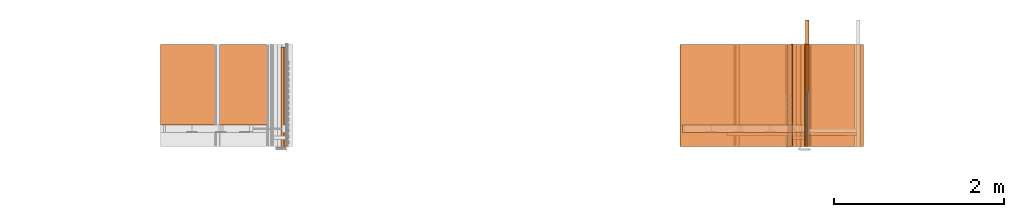
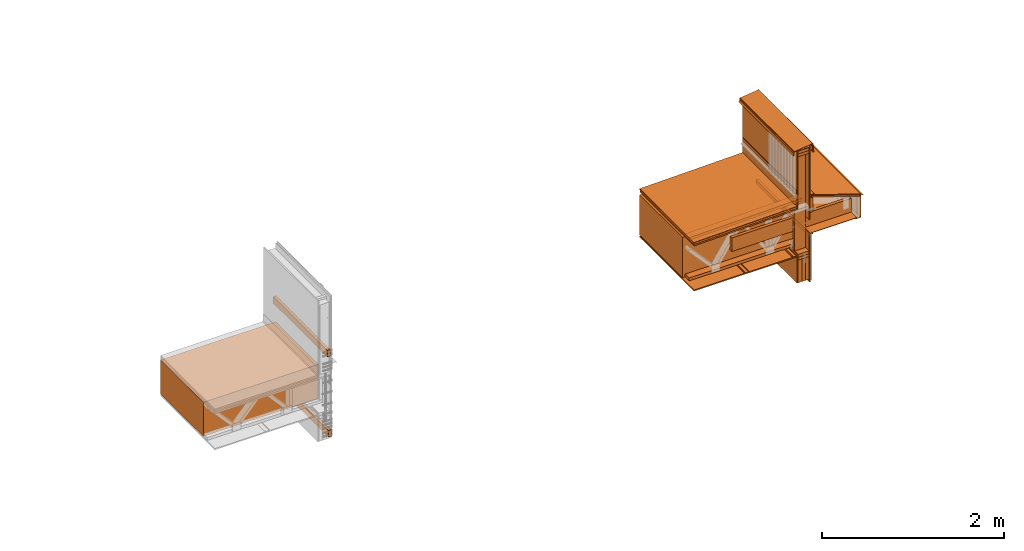
# One storey, part 3 of 22: 39 proxies.
"""IFC2X3 building model written with IfcOpenShell, lengths in feet."""

from ifc_helpers import new_model, entity, si_unit, converted_unit, frame, frame_2d, origin_with_axes, place, context, subcontext, project, spatial, polyline, rectangle, outline, extrude, shape, element, save


model = new_model("IFC2X3")

# Units and contexts
model_context = context("Model", 3, precision=1e-05)
plan_context = context("Plan", 2, precision=1e-05, world=frame_2d((0.0, 0.0, 0.0), x_axis=(1.0, 0.0, 0.0)))
body_context_1 = subcontext(model_context, "Body", "Model", "MODEL_VIEW")
body_context_2 = subcontext(model_context, "Body", "Model", "MODEL_VIEW")
ifc_project = project(units=[converted_unit("VOLUMEUNIT", "cubic foot", entity("IfcReal", 0.0283168467116885), si_unit("VOLUMEUNIT", "CUBIC_METRE"), dimensions=[3, 0, 0, 0, 0, 0, 0]), converted_unit("AREAUNIT", "square foot", entity("IfcReal", 0.09290304), si_unit("AREAUNIT", "SQUARE_METRE"), dimensions=[2, 0, 0, 0, 0, 0, 0]), converted_unit("LENGTHUNIT", "foot", entity("IfcReal", 0.3048), si_unit("LENGTHUNIT", "METRE"), dimensions=[1, 0, 0, 0, 0, 0, 0])], contexts=[model_context, plan_context])

# Site, building, storey
site_placement = place(None, origin_with_axes())
site = spatial("IfcSite", under=ifc_project, at=site_placement, CompositionType="ELEMENT")
building_placement = place(site_placement, origin_with_axes())
building = spatial("IfcBuilding", under=site, at=building_placement, Name="Building", CompositionType="ELEMENT")
storey_placement = place(building_placement, origin_with_axes())
storey = spatial("IfcBuildingStorey", under=building, at=storey_placement, Name="Storey", CompositionType="ELEMENT")

# Proxies
proxy_1_placement = place(storey_placement, frame((1612.24555468622, 1.8910506344217, -61.7362820883123), z_axis=(0.0, 0.0, 1.0), x_axis=(1.0, 0.0, 0.0)))
element("IfcBuildingElementProxy", 1, at=proxy_1_placement, inside=storey, Name="Generic Models 847:Generic Models 1:245", context=body_context_1, shape_type="SweptSolid", body=[
    extrude(rectangle(XDim=4.34660765169413, YDim=3.92583333372057, at=frame_2d((0.0, 0.0, 0.0))), frame((1.09047049612511, 1.96291666644139, 0.0), z_axis=(0.0, 0.0, -1.0), x_axis=(1.0, 0.0, 0.0)), (0.0, 0.0, -1.0), 0.0520833335148361),
])
proxy_2_placement = place(storey_placement, frame((1615.45730951264, 1.8910504388684, -63.2148777718932), z_axis=(0.0, 0.0, 1.0), x_axis=(1.0, 0.0, 0.0)))
element("IfcBuildingElementProxy", 2, at=proxy_2_placement, inside=storey, Name="Generic Models 845:Generic Models 1", context=body_context_1, shape_type="SweptSolid", body=[
    extrude(rectangle(XDim=3.92583333372062, YDim=0.0520833214852274, at=frame_2d((0.0, 0.0, 0.0))), frame((0.0260413497236614, 1.96291666644139, 0.322346925109703), z_axis=(0.0, 0.0, -1.0), x_axis=(-1.63445363909887e-07, 1.0, 0.0)), (-3.6811562686978e-09, 0.0, -1.0), 1.15625032746861),
])
proxy_3_placement = place(storey_placement, frame((1613.4573468386, 1.8910504388684, -61.6841992055337), z_axis=(0.0, 0.0, 1.0), x_axis=(1.0, 0.0, 0.0)))
element("IfcBuildingElementProxy", 3, at=proxy_3_placement, inside=storey, Name="Dowel60:Dowel", context=body_context_1, shape_type="SweptSolid", body=[
    extrude(outline(polyline([(0.00859690791000844, 0.0312147091272387), (0.0601568261743218, 0.0312147457934818), (0.0896196680392806, 0.0606775846029204), (0.0859368189172013, 0.0643604337249997), (0.0579993966526873, 0.0364230053494452), (0.00643947762449387, 0.0364230664598504), (-0.0797915137971793, -0.0498079104481016), (-0.0797914465757336, -0.0792706392588109), (-0.0745831045207233, -0.0792706148146488), (-0.0745831534090474, -0.0519652513596486), (0.00859690791000844, 0.0312147091272387)])), frame((1.88752617735875, 3.88254957492898e-07, 0.0212016271603272), z_axis=(-2.86421364056877e-12, -1.0, -3.20355575240683e-05), x_axis=(-0.707107067108154, -2.26526099140756e-05, 0.707106471061707)), (-2.25479288928909e-05, 2.27436357818078e-05, -1.0), 3.9258333357339),
])
proxy_4_placement = place(storey_placement, frame((1612.20600598753, 1.89104789667555, -59.7213447250406), z_axis=(-0.0209428258240223, -3.9861427580945e-07, 0.999780654907227), x_axis=(0.999780654907227, -4.17451273548863e-09, 0.0209428258240223)))
element("IfcBuildingElementProxy", 4, at=proxy_4_placement, inside=storey, Name="Generic Models 841:Generic Models 1:245", context=body_context_1, shape_type="SweptSolid", body=[
    extrude(rectangle(XDim=4.346574440544, YDim=3.92583333372057, at=frame_2d((0.0, 0.0, 0.0))), frame((1.13210516182456, 1.96291666644139, 0.0), z_axis=(0.0, 0.0, -1.0), x_axis=(-1.0, 0.0, 0.0)), (0.0, 0.0, -1.0), 0.0625000001175565),
])
proxy_5_placement = place(storey_placement, frame((1611.45738416456, 1.8910504388684, -61.6841992055337), z_axis=(0.0, 0.0, 1.0), x_axis=(1.0, 0.0, 0.0)))
element("IfcBuildingElementProxy", 5, at=proxy_5_placement, inside=storey, Name="Dowel60:Dowel", context=body_context_1, shape_type="SweptSolid", body=[
    extrude(outline(polyline([(-0.0916405035833048, -0.0212016210492867), (0.0303084907070624, -0.0212016210492867), (0.0667668637034931, 0.0152567152809009), (0.106276250065468, 0.0152567076421003), (0.106276250065468, 0.0204650435860701), (0.0646095197364258, 0.0204650451138303), (0.0281511467399951, -0.0159932912163573), (-0.0894831596162375, -0.0159932805220364), (-0.108790918793578, 0.00331456726539166), (-0.112473774026698, -0.000368270732684237), (-0.0916405035833048, -0.0212016210492867)])), frame((1.88752559069886, 3.92583411509596, 0.0212016454934487), z_axis=(7.80005029810127e-06, 1.0, -0.000115128779725637), x_axis=(-1.0, 3.20713274959417e-06, 9.87452182243942e-08)), (-7.81993730925024e-06, -0.000115132657811046, -1.0), 3.92583368670996),
])
proxy_6_placement = place(storey_placement, frame((1615.221919663, -0.783451722832177, -57.8829747798249), z_axis=(0.0, 0.0, 1.0), x_axis=(1.0, 0.0, 0.0)))
element("IfcBuildingElementProxy", 6, at=proxy_6_placement, inside=storey, Name="Plane", context=body_context_1, shape_type="SweptSolid", body=[
    extrude(rectangle(XDim=0.129999920355563, YDim=0.458287070881728, at=frame_2d((0.0, 0.0, 0.0))), frame((0.516643596133535, 2.99930689841744, -3.75956218699458), z_axis=(0.0, 0.0, -1.0), x_axis=(0.0, 1.0, 0.0)), (0.0, 0.0, -0.999999940395355), 4.31250712841991),
])
proxy_7_placement = place(storey_placement, frame((1615.25936577264, 0.875491228472842, -61.6011469382939), z_axis=(0.0, 0.0, 1.0), x_axis=(1.0, 0.0, 0.0)))
element("IfcBuildingElementProxy", 7, at=proxy_7_placement, inside=storey, Name="Plane", context=body_context_1, shape_type="SweptSolid", body=[
    extrude(rectangle(XDim=3.92583333372057, YDim=0.0416667373353818, at=frame_2d((0.0, 0.0, 0.0))), frame((0.729220980421452, 2.97847343242075, -1.41638314004332), z_axis=(0.0, 0.0, -1.0), x_axis=(0.0, -1.0, 0.0)), (0.0, 4.55624054040982e-08, -1.0), 2.14599403494259),
])
for number, where, z_axis, x_axis, name in (
    (8, (1615.96773803391, 1.8910506344217, -61.6425354023931), (0.0, 0.0, 1.0), (1.0, 0.0, 0.0), "Generic Models 857:Generic Models 1"),
    (9, (1615.96773803391, 1.8910506344217, -61.7675330695205), (0.0, 0.0, 1.0), (1.0, 0.0, 0.0), "Generic Models 857:Generic Models 1"),
):
    element("IfcBuildingElementProxy", number, at=place(storey_placement, frame(where, z_axis=z_axis, x_axis=x_axis)), inside=storey, Name=name, context=body_context_1, shape_type="SweptSolid", body=[
        extrude(rectangle(XDim=3.92583333372062, YDim=0.458337028879998, at=frame_2d((0.0, 0.0, 0.0))), frame((-0.22916851707018, 1.96291666644139, -0.124999744881169), z_axis=(2.39995301853924e-07, 1.5877549230936e-07, -1.0), x_axis=(0.0, -1.0, -1.5877549230936e-07)), (-3.58418373105907e-13, -1.95553198523157e-07, -1.0), 0.125000025296795),
    ])
for number, where, z_axis, x_axis, name in (
    (10, (1615.83006851316, 1.891050829975, -62.7675331796561), (0.0, 0.0, 1.0), (1.0, 0.0, 0.0), "Generic Models 857:Generic Models 1"),
    (11, (1616.13594515743, 1.891050829975, -62.7675331796561), (0.0, 0.0, 1.0), (1.0, 0.0, 0.0), "Generic Models 857:Generic Models 1"),
    (12, (1615.9825562805, 1.891050829975, -62.7675331796561), (0.0, 0.0, 1.0), (1.0, 0.0, 0.0), "Generic Models 857:Generic Models 1"),
):
    element("IfcBuildingElementProxy", number, at=place(storey_placement, frame(where, z_axis=z_axis, x_axis=x_axis)), inside=storey, Name=name, context=body_context_1, shape_type="SweptSolid", body=[
        extrude(rectangle(XDim=3.92583333372062, YDim=0.152474618603812, at=frame_2d((0.0, 0.0, 0.0))), frame((-0.244431207420945, 1.96291666644139, -0.124999744881169), z_axis=(3.20632494776874e-07, 1.61888749516947e-07, -1.0), x_axis=(0.0, -1.0, -1.61888735306093e-07)), (5.39006101973882e-08, -2.80553450693333e-07, -1.0), 1.00000000188095),
    ])
proxy_8_placement = place(storey_placement, frame((1618.95641817508, 2.42488101867866, -60.8715360245992), z_axis=(0.0, 0.0, 1.0), x_axis=(1.0, 0.0, 0.0)))
element("IfcBuildingElementProxy", 13, at=proxy_8_placement, inside=storey, Name="Generic Models 857:Generic Models 1", context=body_context_1, shape_type="SweptSolid", body=[
    extrude(rectangle(XDim=4.98750469706278, YDim=0.124999990210441, at=frame_2d((0.0, 0.0, 0.0))), frame((-3.48251205416802, -0.0624996524431261, -7.99917073378742e-09), z_axis=(-8.74560586303823e-15, 1.07284883199554e-07, -1.0), x_axis=(1.0, -9.80216086077235e-08, -1.94994878805008e-14)), (1.01429220578098e-08, 2.15060296682168e-07, -1.0), 0.603999939012317),
])
proxy_9_placement = place(storey_placement, frame((1615.25936577264, 0.875491228472842, -57.8051164081403), z_axis=(0.0, 0.0, 1.0), x_axis=(1.0, 0.0, 0.0)))
element("IfcBuildingElementProxy", 14, at=proxy_9_placement, inside=storey, Name="Plane", context=body_context_1, shape_type="SweptSolid", body=[
    extrude(rectangle(XDim=3.92583333372057, YDim=0.0416667373353818, at=frame_2d((0.0, 0.0, 0.0))), frame((0.729220980421452, 2.97847343242075, -2.46242118945585), z_axis=(0.0, 0.0, -1.0), x_axis=(0.0, -1.0, 0.0)), (0.0, 3.06750109757559e-08, -0.999999940395355), 3.18750151662476),
])
proxy_10_placement = place(storey_placement, frame((1616.13434318482, 0.777434450122002, -59.9281180874882), z_axis=(0.0, 0.0, 1.0), x_axis=(1.0, 0.0, 0.0)))
element("IfcBuildingElementProxy", 15, at=proxy_10_placement, inside=storey, Name="Generic Models 857:Generic Models 1", context=body_context_1, shape_type="SweptSolid", body=[
    extrude(rectangle(XDim=4.86265082448525, YDim=0.125000000235114, at=frame_2d((0.0, 0.0, 0.0))), frame((-0.0624994996671132, 3.5449389241186, -0.0325324083495093), z_axis=(1.22221237575104e-07, -5.79981019654952e-07, -1.0), x_axis=(1.43267257612933e-07, 1.0, -5.79981019654952e-07)), (-5.64406036573928e-07, -1.4427088501634e-07, -1.0), 0.636533847540793),
])
proxy_11_placement = place(storey_placement, frame((1615.61670578684, 1.89107136307113, -59.1628883141545), z_axis=(0.315649181604385, 0.0, 0.948875963687897), x_axis=(0.948875963687897, 0.0, -0.315649181604385)))
element("IfcBuildingElementProxy", 16, at=proxy_11_placement, inside=storey, Name="Generic Models 849:Generic Models 1", context=body_context_1, shape_type="SweptSolid", body=[
    extrude(rectangle(XDim=2.14999980285108, YDim=3.92583333372057, at=frame_2d((0.0, 0.0, 0.0))), frame((1.53085515098622, 1.96291666644139, 0.0104166665407792), z_axis=(0.0, 0.0, -1.0), x_axis=(1.0, 0.0, 0.0)), (0.0, 0.0, -1.0), 0.0625000001175565),
])
proxy_12_placement = place(storey_placement, frame((1615.64293808824, 1.89107097196454, -59.0838534938382), z_axis=(-1.3797463616072e-08, -1.0, -4.14766887502083e-08), x_axis=(0.948875963687897, 0.0, -0.315649151802063)))
element("IfcBuildingElementProxy", 17, at=proxy_12_placement, inside=storey, Name="Generic Models 849:Generic Models 1", context=body_context_1, shape_type="SweptSolid", body=[
    extrude(outline(polyline([(0.194672585570124, -0.706612574929015), (0.304858447138093, -0.706612574929015), (0.304858447138093, -0.697664202745818), (0.201180770387018, -0.697664202745818), (-0.498515023334133, 1.40569693460239), (-0.50705493356925, 1.40285603408738), (0.194672585570124, -0.706612574929015)])), frame((1.11466728326843, 0.0487381178064374, -3.92583372398937), z_axis=(1.19706115242479e-07, 0.0, -1.0), x_axis=(-0.315649300813675, 0.948875904083252, 0.0)), (4.35854303759697e-08, 1.32312905520848e-07, -1.0), 3.92583333372061),
])
proxy_13_placement = place(storey_placement, frame((1615.6457415403, 1.89107097196454, -59.0753117258467), z_axis=(0.315649181604385, 0.0, 0.948875963687897), x_axis=(0.948875963687897, 0.0, -0.315649181604385)))
element("IfcBuildingElementProxy", 18, at=proxy_13_placement, inside=storey, Name="Generic Models 849:Generic Models 1", context=body_context_1, shape_type="SweptSolid", body=[
    extrude(rectangle(XDim=2.14999980285108, YDim=3.92583333372057, at=frame_2d((0.0, 0.0, 0.0))), frame((1.53085515098622, 1.96291666644139, 0.0104166665407792), z_axis=(0.0, 0.0, -1.0), x_axis=(-1.0, 0.0, 0.0)), (0.0, 0.0, -1.0), 0.0100000003555754),
])
proxy_14_placement = place(storey_placement, frame((1616.15637030814, 1.89113120237986, -59.2476426772871), z_axis=(0.0, 1.0, -1.62920684942947e-07), x_axis=(1.0, 0.0, 0.0)))
element("IfcBuildingElementProxy", 19, at=proxy_14_placement, inside=storey, Name="Vert", shapes=[
    shape(model_context, None, "SweptSolid", [extrude(outline(polyline([(-0.0688364714618743, -0.0695616625288496), (0.0145624858006991, -0.0695616625288496), (0.0145624858006991, 0.0168997097731106), (0.0474392375334354, 0.11573088528916), (0.0424660452619547, 0.117385241733448), (0.00932134655512028, 0.017748591355647), (0.00932134044407977, -0.0643205286304312), (-0.0688364714618743, -0.0643205286304312), (-0.0688364714618743, -0.0695616625288496)])), frame((-0.0685154401704552, -0.074540797787232, -8.33101503327495e-05), z_axis=(-4.32977848019434e-10, 1.33450876091956e-05, -1.0), x_axis=(0.0, 1.0, 1.33452413138002e-05)), (1.32982595459907e-05, -1.59991948578408e-08, -1.0), 3.9258333340677)]),
])
proxy_15_placement = place(storey_placement, frame((1616.21774588357, 0.875491228472842, -58.3669457222846), z_axis=(0.0, 0.0, 1.0), x_axis=(1.0, 0.0, 0.0)))
element("IfcBuildingElementProxy", 20, at=proxy_15_placement, inside=storey, Name="Plane", context=body_context_1, shape_type="SweptSolid", body=[
    extrude(rectangle(XDim=0.0416667373353818, YDim=3.92583333372057, at=frame_2d((0.0, 0.0, 0.0))), frame((-0.729220980421452, 2.97847343242075, -1.22356250530153), z_axis=(0.0, 0.0, -1.0), x_axis=(-1.0, 0.0, 0.0)), (-3.89475118822702e-08, 0.0, -0.999999940395355), 2.51047214359348),
])
proxy_16_placement = place(storey_placement, frame((1614.48781571676, 0.875498268391517, -57.6130423958846), z_axis=(-0.0623385570943356, -0.998051762580872, 0.00255164504051208), x_axis=(0.997216582298279, -0.0623907595872879, -0.0408231504261494)))
element("IfcBuildingElementProxy", 21, at=proxy_16_placement, inside=storey, Name="Plane", context=body_context_1, shape_type="SweptSolid", body=[
    extrude(rectangle(XDim=0.0830000892507013, YDim=4.3049496744137, at=frame_2d((0.0, 0.0, 0.0))), frame((-1.39688755192469, -2.02862179185462, -4.86372297830156), z_axis=(-0.0623802654445171, -2.24446893071217e-07, -0.998052477836609), x_axis=(-0.0622801221907139, 0.998051106929779, 0.0038922131061554)), (-1.25366568681784e-06, 6.22649451997859e-08, -1.0), 3.92583055549879),
])
proxy_17_placement = place(storey_placement, frame((1612.1906871245, 1.89104848333544, -59.8682193305549), z_axis=(-0.0623933188617229, 0.998051643371582, -7.58967132696853e-07), x_axis=(-0.998051643371582, -0.0623933188617229, -1.47461420851869e-07)))
element("IfcBuildingElementProxy", 22, at=proxy_17_placement, inside=storey, Name="Generic Models 849:Generic Models 1", context=body_context_1, shape_type="SweptSolid", body=[
    extrude(outline(polyline([(-0.192026553915085, -1.4385472484461), (0.467256757765617, -1.43854734622274), (0.467256268882376, -1.42856865260858), (-0.182670428664509, -1.42794268650646), (-0.274917770793119, 2.86711502106484), (-0.284898248831118, 2.86649081494239), (-0.192026553915085, -1.4385472484461)])), frame((-1.83485389694454, 0.552786489718855, -0.11470639379084), z_axis=(0.0624101869761944, 7.61111323299701e-06, -0.998050570487976), x_axis=(-4.98313129355665e-05, 0.999999940395355, 5.09806977788685e-06)), (8.11445261206245e-06, 5.07493780332879e-07, -1.0), 3.92583415097491),
])
proxy_18_placement = place(storey_placement, frame((1617.99673646141, 0.954266256234777, -60.8977996145333), z_axis=(0.0, 0.0, 1.0), x_axis=(1.0, 0.0, 0.0)))
element("IfcBuildingElementProxy", 23, at=proxy_18_placement, inside=storey, Name="Vert", context=body_context_2, shape_type="SweptSolid", body=[
    extrude(outline(polyline([(-0.0111396683274898, -0.490149155532907), (0.0949420909986408, -0.490149204421231), (-0.215878959481172, 0.444216717259465), (0.000437889997880989, 0.516175441541697), (0.00193634888113249, 0.51606803389359), (0.00291996630302232, 0.514932553677421), (0.00652634300990641, 0.504091323360683), (0.00641893536179984, 0.502592847337873), (0.00528342191684805, 0.501609263144766), (-0.0624072107332429, 0.479091692158556), (-0.0607528542889541, 0.474118380721786), (0.0079270179403012, 0.496965116794341), (0.0114914587774654, 0.500052707792893), (0.0118286209242062, 0.504756400122104), (0.00756406949422374, 0.51757609202793), (0.00447644564882899, 0.521140539740014), (-0.000227226103363275, 0.521477771399841), (-0.222506505141421, 0.447535550031136), (0.0876750860588131, -0.484908082744894), (-0.0121821629511696, -0.484907984968245), (-0.0165390163009835, -0.48671250190009), (-0.0186585695935007, -0.491829349456497), (-0.0147588457545544, -0.504763880035696), (-0.013251129838484, -0.508404055761853), (-0.00889425204450807, -0.51020871935867), (0.230152590146528, -0.510208768246994), (0.23015261459069, -0.504967842123953), (-0.00785180630915238, -0.504967597682332), (-0.00923964805446389, -0.504392719878925), (-0.00981643250251184, -0.503000087077849), (-0.0131006760209838, -0.492106986249213), (-0.0125277056260978, -0.490724033336314), (-0.0111396683274898, -0.490149155532907)])), frame((0.0629414928945031, 0.936796698044604, 0.475318589079098), z_axis=(-5.63370304007549e-06, -1.0, -5.26309213455534e-06), x_axis=(-0.948876440525055, 3.68684163731814e-06, 0.315648019313812)), (1.50467329262938e-07, -7.08179868524894e-06, -1.0), 3.92582941161867),
])
proxy_19_placement = place(storey_placement, frame((1615.96773803391, 1.8910506344217, -57.0800360732191), z_axis=(0.0, 0.0, 1.0), x_axis=(1.0, 0.0, 0.0)))
element("IfcBuildingElementProxy", 24, at=proxy_19_placement, inside=storey, Name="Generic Models 857:Generic Models 1", context=body_context_1, shape_type="SweptSolid", body=[
    extrude(rectangle(XDim=3.92583333372062, YDim=0.458337028879998, at=frame_2d((0.0, 0.0, 0.0))), frame((-0.22916851707018, 1.96291666644139, -0.124999744881169), z_axis=(2.39995301853924e-07, 1.5877549230936e-07, -1.0), x_axis=(0.0, 1.0, 1.5877549230936e-07)), (3.58418373105907e-13, 1.95553198523157e-07, -1.0), 0.125000025296795),
])
proxy_20_placement = place(storey_placement, frame((1616.18250248626, 1.89104809222885, -57.3500060033923), z_axis=(0.0, 0.0, 1.0), x_axis=(1.0, 0.0, 0.0)))
element("IfcBuildingElementProxy", 25, at=proxy_20_placement, inside=storey, Name="Walls 112:Walls 26", context=body_context_1, shape_type="SweptSolid", body=[
    extrude(outline(polyline([(0.386499357348665, -6.46831232495381e-09), (0.382584942568318, 0.00362836575842025), (0.332265828303465, 0.0394786569947411), (0.327974093437508, 0.0435731702501301), (0.325010189898996, 0.0487111986729651), (0.221538687432845, 0.307484263471105), (0.219125290868163, 0.311889150363254), (0.215727796782972, 0.315588456517442), (0.211543738450904, 0.318367048863351), (0.206816213063681, 0.320063595931361), (0.201820095223705, 0.320579343306737), (0.196845708243803, 0.319884420223436), (0.192182202117024, 0.318019135104703), (-0.485563088511545, -0.0534007042216191), (-0.495159817649311, -0.0646335544587746), (-0.494895087374164, -0.0794052838144966), (-0.47081348112249, -0.139631201412891), (-0.469416155042298, -0.145412245740884), (-0.469709289433762, -0.151352568228883), (-0.483599537861316, -0.222600492944555), (-0.465207554771518, -0.225915121320352), (-0.45483247462533, -0.225145472433623), (-0.446123264123761, -0.21945482261694), (-0.429113549510325, -0.200814022401499), (-0.433960582405876, -0.196391144606072), (-0.450970248130989, -0.215031944821513), (-0.456936383654126, -0.218930202010735), (-0.464043817104004, -0.219457487030605), (-0.475885644750645, -0.21732338946166), (-0.463268839389946, -0.152608167057432), (-0.462883501619179, -0.144796949515505), (-0.46472067595154, -0.137194998445004), (-0.488802282203214, -0.07696908084661), (-0.488983657885724, -0.0668498821889009), (-0.482409644940394, -0.0591549577479913), (0.195335657910256, 0.31226488157833), (0.207014968545418, 0.313182295424732), (0.215446004482705, 0.305048084947381), (0.318917531393019, 0.0462750232047609), (0.322814908592407, 0.0395187118098022), (0.32845840562047, 0.0341345856743535), (0.378777519885323, -0.00171571721113837), (0.384573377375528, -0.0109903076223618), (0.382102561474159, -0.0216442101031268), (0.377990882305961, -0.0273902244191235), (0.338912489298448, -0.0241339962020164), (0.338367628926054, -0.0306730203848733), (0.374848291942767, -0.033712795546909), (0.379882127124806, -0.0319383968782472), (0.384299896090362, -0.0289432200898961), (0.3878116666332, -0.0249238512442103), (0.390186930305063, -0.0201440902104176), (0.391269782240309, -0.0149177037805241), (0.390989114371497, -0.00958768327004249), (0.389363430929309, -0.00450388765820544), (0.386499357348665, -6.46831232495381e-09)])), frame((-0.35987416492516, -3.36724384158687e-07, 0.170695062560516), z_axis=(-2.40618358571254e-11, -1.0, -6.80640296195634e-05), x_axis=(0.928523361682892, 2.5270401238231e-05, -0.371274083852768)), (2.8366519472911e-05, -6.17389305261895e-05, -1.0), 3.92583334278209),
])
proxy_21_placement = place(storey_placement, frame((1616.18250248626, 1.89104809222885, -57.3500060033923), z_axis=(0.0, 0.0, 1.0), x_axis=(1.0, 0.0, 0.0)))
element("IfcBuildingElementProxy", 26, at=proxy_21_placement, inside=storey, Name="Walls 112:Walls 26", context=body_context_1, shape_type="SweptSolid", body=[
    extrude(outline(polyline([(0.198214239101084, 5.39266502552206e-09), (0.190805885794125, 0.00155078576574606), (0.183255939678414, 0.00101517139765339), (-0.0549143172917873, -0.0496026130974919), (-0.0585102490846097, -0.0499005446557611), (-0.0620659824529188, -0.0492870756314965), (-0.0653541866895251, -0.0478014511268909), (-0.0681647397773316, -0.04553863060052), (-0.0703179649030912, -0.0426432440482725), (-0.0716761925460629, -0.0393003826652925), (-0.0721525970425975, -0.0357237189832165), (-0.0717167698550881, -0.0321418975829452), (-0.0703965773282871, -0.0287838319311618), (-0.0222233473017734, 0.0591172709611301), (-0.0210522458304375, 0.0626084656305513), (-0.0211690522588574, 0.0662889681130726), (-0.0663304865223373, 0.278785668333059), (-0.0728250070526375, 0.277405379833825), (-0.0281510061860632, 0.0672022203408827), (-0.0280342242018053, 0.0635217056362804), (-0.0292053073400196, 0.0600305231889402), (-0.0761507697442542, -0.0256303012776836), (-0.0780779719254946, -0.0305322861773135), (-0.0787141862425591, -0.0357609535530796), (-0.0780186948324908, -0.0409820554606871), (-0.0760359799592044, -0.0458618740886059), (-0.0728928151582013, -0.0500884530405829), (-0.0687900642201969, -0.0533916659926961), (-0.063990019115172, -0.0555603337178393), (-0.0587994724101438, -0.0564558394839914), (-0.053550265827204, -0.0560209472856809), (0.184620009476119, -0.00540315515173506), (0.190361588704461, -0.00499583291271188), (0.195995479176833, -0.0061751766499435), (0.256903694448821, -0.0280596369637905), (0.259122466595154, -0.0218844595499669), (0.198214239101084, 5.39266502552206e-09)])), frame((-0.102937641966687, 3.92583411509596, 0.270357345697761), z_axis=(-2.0425753177733e-07, 1.0, 1.33545736389351e-05), x_axis=(0.207884714007378, -3.94630205846624e-06, -0.978153347969055)), (3.86431111110142e-07, -1.29666614157031e-06, -1.0), 3.92583366057402),
])
proxy_22_placement = place(storey_placement, frame((1616.1879091438, 1.89104809222885, -57.3500060033923), z_axis=(0.0, 0.0, 1.0), x_axis=(1.0, 0.0, 0.0)))
element("IfcBuildingElementProxy", 27, at=proxy_22_placement, inside=storey, Name="Walls 112:Walls 26", context=body_context_1, shape_type="SweptSolid", body=[
    extrude(outline(polyline([(0.0481024320943775, 3.27095830736051e-08), (0.0453387506873276, -0.00287266971397989), (-0.0190843884244053, -0.0310282246148571), (-0.0215139303581295, -0.0325150224392417), (-0.0234498346610645, -0.0346043444143271), (-0.0614582211404961, -0.0889659578132191), (-0.0560806154852777, -0.0927258671562033), (-0.0190739385451232, -0.0397968833185635), (-0.0171379853538641, -0.0377076652311669), (-0.0147084800863829, -0.0362208246294986), (0.0491390601191621, -0.00831683663152686), (0.0546665451540722, -0.00257143208279159), (0.0545124491564245, 0.00539965046999922), (-0.0306555336424372, 0.200273781975736), (-0.0366211069498475, 0.197666579872135), (0.0480254574280398, 0.00398545791798337), (0.0481024320943775, 3.27095830736051e-08)])), frame((-0.80930758414306, 3.92583372398937, 0.23708260786815), z_axis=(-2.89606032310985e-06, 1.0, -3.36716802848969e-05), x_axis=(-0.400465697050095, 2.43921167566441e-05, 0.916311681270599)), (-1.55662235101772e-06, -7.43598502594978e-06, -1.0), 3.92583366068372),
])
proxy_23_placement = place(storey_placement, frame((1615.44879903318, 1.8911012827255, -58.8989633274829), z_axis=(0.0, 1.0, -1.62920684942947e-07), x_axis=(1.0, 0.0, 0.0)))
element("IfcBuildingElementProxy", 28, at=proxy_23_placement, inside=storey, Name="Vert", context=body_context_2, shape_type="SweptSolid", body=[
    extrude(outline(polyline([(1.0857317508675, -6.11512663195532e-09), (1.09089514010847, 0.000683672657710674), (1.06833034300116, 0.171104111168485), (-0.659322801224516, -0.0576467590597202), (-0.682300264675786, -0.0428262238789184), (-0.810935223118214, -0.0598582224015958), (-0.810247266621101, -0.0650540184904271), (-0.684492074911363, -0.0484033152852159), (-0.661514611460092, -0.0632238535215379), (1.06385510581059, 0.165224666866105), (1.0857317508675, -6.11512663195532e-09)])), frame((0.0430676435900173, -0.742585777141291, -3.01397592448043e-05), z_axis=(-1.42204953590408e-07, 4.33815969813622e-08, -1.0), x_axis=(0.131259962916374, -0.991347968578339, -6.1660649919304e-08)), (1.21642551675905e-06, -3.75059805435285e-08, -1.0), 3.92582941152308),
])
proxy_24_placement = place(storey_placement, frame((1614.96089825167, 1.89104789667555, -60.8915356513396), z_axis=(0.0, 0.0, 1.0), x_axis=(1.0, 0.0, 0.0)))
element("IfcBuildingElementProxy", 29, at=proxy_24_placement, inside=storey, Name="Generic Models 841:Generic Models 1:245", context=body_context_1, shape_type="SweptSolid", body=[
    extrude(rectangle(XDim=1.95334235530076, YDim=3.92583333372057, at=frame_2d((0.0, 0.0, 0.0))), frame((2.03011973010586, 1.96291666644139, 0.0), z_axis=(0.0, 0.0, -1.0), x_axis=(1.0, 0.0, 0.0)), (0.0, 0.0, -0.999999940395355), 0.0199999997321788),
])
proxy_25_placement = place(storey_placement, frame((1616.01439548603, 1.89101856368107, -60.8915669398671), z_axis=(0.0, 0.0, 1.0), x_axis=(1.0, 0.0, 0.0)))
element("IfcBuildingElementProxy", 30, at=proxy_25_placement, inside=storey, Name="Vert", context=body_context_2, shape_type="SweptSolid", body=[
    extrude(outline(polyline([(-0.120581120369941, 0.0468750021070868), (0.0575438858036763, 0.0468750021070868), (0.0575438858036763, -0.046875005162607), (0.00025222097521066, -0.046875005162607), (0.00025222097521066, -0.0521161390610254), (0.0627850319241758, -0.0521161390610254), (0.0627850319241758, 0.0521161451720659), (-0.120581120369941, 0.0521161451720659), (-0.120581120369941, 0.0468750021070868)])), frame((0.0520833349955363, 0.0, -0.0627522217476462), z_axis=(0.0, -1.0, 0.0), x_axis=(0.0, 0.0, 1.0)), (0.0, 0.0, -1.0), 3.92586307694604),
])
proxy_26_placement = place(storey_placement, frame((1616.00938932163, 1.89101856368107, -60.8915669398671), z_axis=(0.0, 0.0, 1.0), x_axis=(1.0, 0.0, 0.0)))
element("IfcBuildingElementProxy", 31, at=proxy_26_placement, inside=storey, Name="Vert", context=body_context_2, shape_type="SweptSolid", body=[
    extrude(outline(polyline([(-1.96293152849192, -0.00262057172345961), (1.96293152849192, -0.00262057172345961), (1.96293152849192, 0.00262057153248959), (-1.96293152849192, 0.00262057153248959), (-1.96293152849192, -0.00262057172345961)])), frame((0.00258776135595999, 1.96293152849192, -2.12596294291689), z_axis=(0.0, 0.0, -1.0), x_axis=(0.0, 1.0, 0.0)), (0.0, 0.0, -0.999999940395355), 2.14599186743865),
])
proxy_27_placement = place(storey_placement, frame((1595.08232056625, 0.875493770665697, -59.9454707048071), z_axis=(0.0, 0.0, 1.0), x_axis=(1.0, 0.0, 0.0)))
element("IfcBuildingElementProxy", 32, at=proxy_27_placement, inside=storey, Name="Plane", context=body_context_1, shape_type="SweptSolid", body=[
    extrude(rectangle(XDim=4.8049778991205, YDim=3.10033562211458, at=frame_2d((0.0, 0.0, 0.0))), frame((-1.51710658092198, 3.39122229986616, -1.69706332871294), z_axis=(0.0, 0.0, -1.0), x_axis=(1.0, 0.0, 0.0)), (0.0, 0.0, -1.0), 1.49999431547957),
])
proxy_28_placement = place(storey_placement, frame((1612.10918676822, 2.42488297421162, -61.5571052070678), z_axis=(-0.0209425892680883, -9.57606630436203e-07, 0.999780595302582), x_axis=(0.999780595302582, -1.00284847093235e-08, 0.0209425892680883)))
element("IfcBuildingElementProxy", 33, at=proxy_28_placement, inside=storey, Name="Generic Models 855:Generic Models 1", context=body_context_1, shape_type="SweptSolid", body=[
    extrude(rectangle(XDim=4.70100164291481, YDim=0.291666664589754, at=frame_2d((0.0, 0.0, 0.0))), frame((1.54728593006535, 0.145833528651966, 1.70833482517032), z_axis=(0.0, 0.0, -1.0), x_axis=(-1.0, 0.0, 0.0)), (0.0, 0.0, -1.0), 0.125000015272121),
])
proxy_29_placement = place(storey_placement, frame((1612.0699384394, 2.42488121423196, -61.6425354023931), z_axis=(0.0, 0.0, 1.0), x_axis=(1.0, 0.0, 0.0)))
element("IfcBuildingElementProxy", 34, at=proxy_29_placement, inside=storey, Name="Generic Models 855:Generic Models 1", context=body_context_1, shape_type="SweptSolid", body=[
    extrude(rectangle(XDim=4.70100164291481, YDim=0.291666664589754, at=frame_2d((0.0, 0.0, 0.0))), frame((1.54728593006535, 0.145833528651966, 0.0), z_axis=(0.0, 0.0, -1.0), x_axis=(-1.0, 0.0, 0.0)), (0.0, 0.0, -1.0), 0.125000000235113),
])
proxy_30_placement = place(storey_placement, frame((1615.08234779979, 0.875493770665697, -59.9454707048071), z_axis=(0.0, -1.0, -4.37113882867379e-08), x_axis=(1.0, 0.0, 0.0)))
element("IfcBuildingElementProxy", 35, at=proxy_30_placement, inside=storey, Name="Plane", context=body_context_1, shape_type="SweptSolid", body=[
    extrude(outline(polyline([(-2.33187587085984, -0.912696123123169), (2.37010517145392, -0.912696123123169), (2.33084510943395, 0.961911510138374), (-2.36907460558133, 0.863480638331316), (-2.33187587085984, -0.912696123123169)])), frame((-1.56912062894015, -0.784167350120745, -4.94139009886213), z_axis=(0.0, 0.0, -1.0), x_axis=(0.999780714511871, 0.0209385100752115, 0.0)), (1.47831746843963e-08, -4.63206148992867e-08, -1.0), 3.10033562211458),
])
proxy_31_placement = place(storey_placement, frame((1615.96773803391, 1.8910506344217, -57.2050337403465), z_axis=(0.0, 0.0, 1.0), x_axis=(1.0, 0.0, 0.0)))
element("IfcBuildingElementProxy", 36, at=proxy_31_placement, inside=storey, Name="Generic Models 857:Generic Models 1", context=body_context_1, shape_type="SweptSolid", body=[
    extrude(rectangle(XDim=3.92583333372062, YDim=0.458337028879998, at=frame_2d((0.0, 0.0, 0.0))), frame((-0.22916851707018, 1.96291666644139, -0.124999744881169), z_axis=(2.39995301853924e-07, 1.5877549230936e-07, -1.0), x_axis=(0.0, -1.0, -1.5877549230936e-07)), (-3.58418373105907e-13, -1.95553198523157e-07, -1.0), 0.125000025296795),
])
proxy_32_placement = place(storey_placement, frame((1616.02991459564, 1.8911012827255, -59.0922638500143), z_axis=(-2.2670858856118e-14, 1.0, -1.62920684942947e-07), x_axis=(1.0, 2.2670858856118e-14, 1.82812812841114e-15)))
element("IfcBuildingElementProxy", 37, at=proxy_32_placement, inside=storey, Name="Vert", context=body_context_2, shape_type="SweptSolid", body=[
    extrude(outline(polyline([(-1.21231457301638, 0.0262368816315267), (0.771407693076947, 0.0262368816315267), (0.792241012408665, 0.0387368775082855), (0.869093897930906, 0.0387368683417247), (0.869093897930906, 0.0439780052956634), (0.789336165965698, 0.0439780266843052), (0.768502846633981, 0.0314780277520262), (-1.21752293951555, 0.0314780216409857), (-1.21752293951555, -0.140429792187502), (-1.21231457301638, -0.140429792187502), (-1.21231457301638, 0.0262368816315267)])), frame((-0.0451547044801118, -0.799912177124048, -3.04061713690116e-05), z_axis=(4.52850542842498e-07, -1.80981430730753e-07, -1.0), x_axis=(-1.54029642374098e-08, 1.0, -1.80049212872291e-07)), (-1.42516989853902e-06, 1.06301843061374e-06, -1.0), 3.92582941152638),
])
for number, where, z_axis, x_axis, name in (
    (38, (1595.63440037525, 1.79105054518682, -59.2050402183232), (0.0, 0.0, 1.0), (-1.62920684942947e-07, 1.0, 0.0), "Generic Models 857:Generic Models 1"),
    (39, (1595.67605166298, 1.79105054518682, -62.7550427995016), (0.0, 0.0, 1.0), (-1.62920684942947e-07, 1.0, 0.0), "Generic Models 857:Generic Models 1"),
):
    element("IfcBuildingElementProxy", number, at=place(storey_placement, frame(where, z_axis=z_axis, x_axis=x_axis)), inside=storey, Name=name, context=body_context_1, shape_type="SweptSolid", body=[
        extrude(rectangle(XDim=0.125000000235113, YDim=3.92583333372057, at=frame_2d((0.0, 0.0, 0.0))), frame((1.96291666644139, -0.229193596780457, 0.0), z_axis=(0.0, 0.0, -1.0), x_axis=(0.0, 1.0, 0.0)), (0.0, 0.0, -0.999999940395355), 0.290999995168469),
    ])

save(model, "model.ifc")
